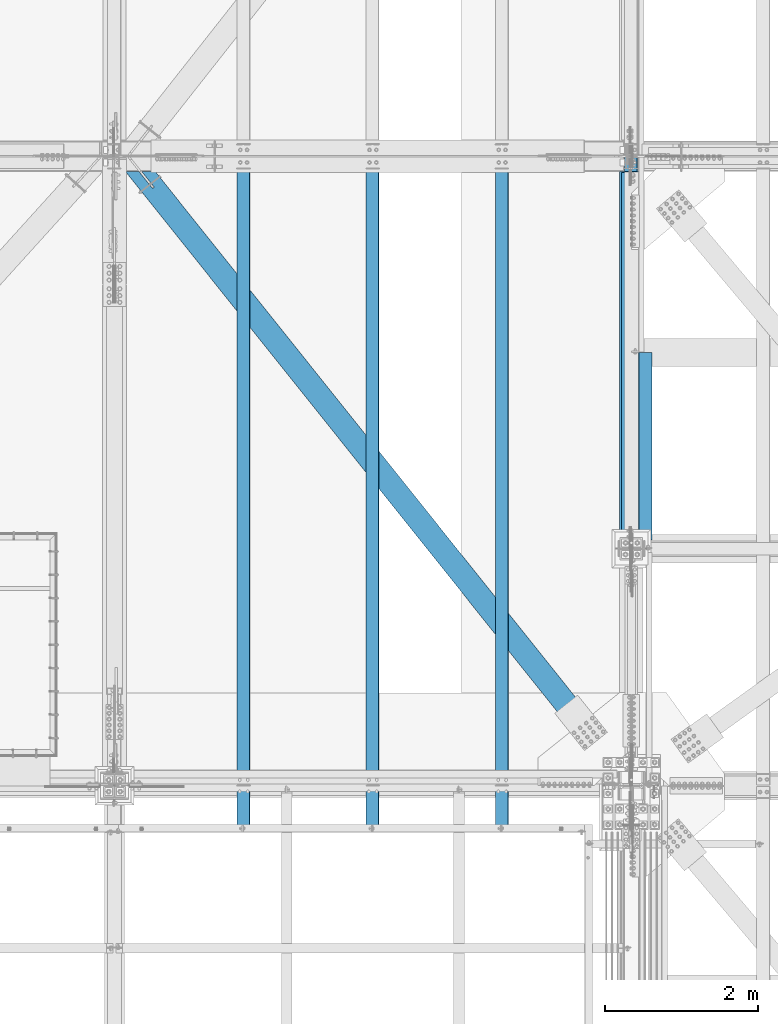
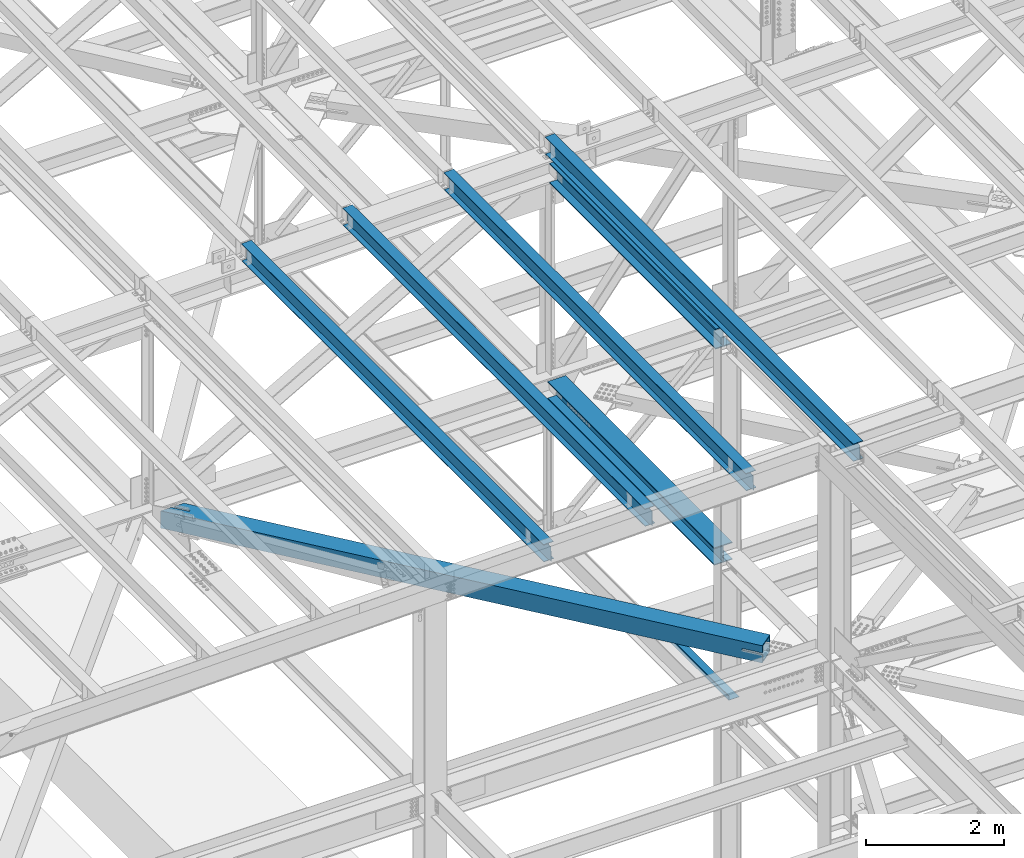
# One storey, part 1802 of 3843: 8 beams, 8 elements without a shape of their own.
"""IFC2X3 building model written with IfcOpenShell, lengths in millimetres."""

from ifc_helpers import new_model, si_unit, frame, origin_with_axes, place, context, subcontext, project, spatial, faceted_brep, material, type_object, element, aggregate, save


model = new_model("IFC2X3")

# Units and contexts
model_context = context("Model", 3, precision=1e-05, world=origin_with_axes())
body_context = subcontext(model_context, "Body", "Model", "MODEL_VIEW")
ifc_project = project(units=[si_unit("LENGTHUNIT", "METRE", prefix="MILLI"), si_unit("AREAUNIT", "SQUARE_METRE"), si_unit("VOLUMEUNIT", "CUBIC_METRE"), si_unit("MASSUNIT", "GRAM", prefix="KILO"), si_unit("TIMEUNIT", "SECOND"), si_unit("PLANEANGLEUNIT", "RADIAN"), si_unit("SOLIDANGLEUNIT", "STERADIAN"), si_unit("THERMODYNAMICTEMPERATUREUNIT", "DEGREE_CELSIUS"), si_unit("LUMINOUSINTENSITYUNIT", "LUMEN")], contexts=[model_context])

# Site, building, storey
site_placement = place(None, origin_with_axes())
site = spatial("IfcSite", under=ifc_project, at=site_placement, CompositionType="ELEMENT")
building_placement = place(site_placement, origin_with_axes())
building = spatial("IfcBuilding", under=site, at=building_placement, Name="Undefined", CompositionType="ELEMENT")
storey_placement = place(building_placement, origin_with_axes())
storey = spatial("IfcBuildingStorey", under=building, at=storey_placement, Name="Undefined", CompositionType="ELEMENT", Elevation=0.0)

# Assembly, beam
assembly_1_placement = place(storey_placement, origin_with_axes())
assembly_1 = element("IfcElementAssembly", 1, at=assembly_1_placement, inside=storey, Name="BEAM", AssemblyPlace="NOTDEFINED", PredefinedType="RIGID_FRAME")
ifc_material_1 = material(Name="STEEL/A992")
beam_type_1 = type_object("IfcBeamType", Name="W12X26", PredefinedType="NOTDEFINED")
beam_1_placement = place(assembly_1_placement, frame((75320.4092622759, 25005.9853702349, 46393.69347119), z_axis=(-0.021152098282546, -0.00202236699979404, 0.999774223897558), x_axis=(0.0, 0.999997954099553, 0.00202281900020155)))
beam_1 = element("IfcBeam", 2, at=beam_1_placement, type_object=beam_type_1, material=ifc_material_1, Name="BEAM", ObjectType="W12X26", context=body_context, shape_type="Brep", body=[
    faceted_brep([(20.6890464579228, -3.17499999946449, -130.175000019226), (20.6887747607652, 3.17500000055588, -130.175000019204), (77.7840105210125, 3.17500000055588, -130.175000018884), (77.7840105210162, -3.17499999946449, -130.175000018848), (82.6440900390589, 3.17500000058499, -131.141729941497), (82.6440900390626, -3.17499999946449, -131.141729941461), (86.7642665072199, 3.17500000058499, -133.894743842022), (86.7642665072199, -3.17499999944994, -133.894743841985), (89.5172804076938, 3.17500000061409, -138.014920310212), (89.5172804076974, -3.17499999942083, -138.014920310183), (90.4840103302849, -3.17499999942083, -142.874999828266), (90.4840103302813, 3.17500000062864, -142.874999828302), (90.4840103302158, 3.17500000062864, -146.050000000549), (90.4840103302158, 82.5500000010652, -146.050000000607), (90.4840103301649, 82.5500000011089, -155.575000000623), (90.4840103301758, -82.5499999997846, -155.575000000514), (90.4840103302231, -82.5499999998283, -146.050000000498), (90.4840103302158, -3.17499999939173, -146.050000000556), (8827.13158785976, -82.5500000004686, 146.049999971365), (8827.15085093943, -82.5500000005122, 155.574999971373), (90.484010334254, -82.5500000010652, 155.420462696282), (90.4840103342431, -82.5500000010652, 146.050000000017), (8827.1437868134, 82.5500000003958, 155.574999971279), (90.4840103342431, 82.5499999997992, 155.574999999917), (8827.12452373372, 82.5500000004395, 146.049999971256), (90.4840103342322, 82.5499999998428, 146.049999999908), (8827.12791994816, 3.17500000000291, 146.049999971314), (90.4840103342394, 3.17499999940628, 146.049999999959), (77.784010525178, -3.17500000057044, 130.174999981173), (77.7840105251707, 3.17499999946449, 130.174999981136), (21.2152989384304, 3.17499999946449, 130.174999980234), (21.2155706355879, -3.17500000057044, 130.174999980212), (82.6440900432135, -3.17500000057044, 131.141729903742), (82.6440900432099, 3.17499999946449, 131.141729903706), (86.7642665113563, -3.17500000058499, 133.894743804216), (86.7642665113526, 3.17499999943539, 133.894743804187), (89.5172804118192, -3.17500000059954, 138.014920272384), (89.5172804118156, 3.17499999943539, 138.014920272348), (90.4840103343886, -3.17500000061409, 142.874999790452), (90.4840103343849, 3.17499999943539, 142.874999790416), (90.4840103342394, -3.17500000062864, 146.049999999959), (8827.12819164533, -3.17500000003201, 146.049999971314), (8826.53718550493, 3.17500000122527, -146.050000029201), (8826.53745720208, -3.1749999987951, -146.050000029194), (8826.54085341652, -82.5499999992317, -146.05000002915), (8826.52159033686, -82.549999999188, -155.575000029159), (8826.51452621082, 82.5500000017055, -155.575000029276), (8826.5337892905, 82.5500000016764, -146.050000029252), (20.7233868324729, 3.17500000049768, -113.060395883127), (21.1897445320101, 3.1749999995227, 117.539132543461)], [[[0, 1, 2, 3]], [[3, 2, 4, 5]], [[5, 4, 6, 7]], [[7, 6, 8, 9]], [[10, 11, 12, 13, 14, 15, 16, 17]], [[9, 8, 11, 10]], [[18, 19, 20, 21]], [[19, 22, 23, 20]], [[22, 24, 25, 23]], [[24, 26, 27, 25]], [[28, 29, 30, 31]], [[32, 33, 29, 28]], [[34, 35, 33, 32]], [[36, 37, 35, 34]], [[38, 39, 37, 36]], [[20, 23, 25, 27, 39, 38, 40, 21]], [[41, 18, 21, 40]], [[42, 26, 24, 22, 19, 18, 41, 43, 44, 45, 46, 47]], [[44, 43, 17, 16]], [[45, 44, 16, 15]], [[46, 45, 15, 14]], [[47, 46, 14, 13]], [[42, 47, 13, 12]], [[6, 4, 2, 1, 48, 49, 30, 29, 33, 35, 37, 39, 27, 26, 42, 12, 11, 8]], [[31, 30, 49, 48, 1, 0]], [[43, 41, 40, 38, 36, 34, 32, 28, 31, 0, 3, 5, 7, 9, 10, 17]]]),
])
aggregate(assembly_1, [beam_1])

assembly_2_placement = place(storey_placement, origin_with_axes())
assembly_2 = element("IfcElementAssembly", 3, at=assembly_2_placement, inside=storey, Name="BEAM", AssemblyPlace="NOTDEFINED", PredefinedType="RIGID_FRAME")
beam_2_placement = place(assembly_2_placement, frame((77009.5092622784, 24866.2620305877, 46429.4293898956), z_axis=(-0.0211520979065535, -0.00217161999968084, 0.999773910852213), x_axis=(0.0, 0.999997639304329, 0.00217287500066101)))
beam_2 = element("IfcBeam", 4, at=beam_2_placement, type_object=beam_type_1, material=ifc_material_1, Name="BEAM", ObjectType="W12X26", context=body_context, shape_type="Brep", body=[
    faceted_brep([(3.23033224151368, -3.17500000062864, -130.174999994553), (3.23004038932413, 3.17499999939173, -130.174999994582), (41.2712136226364, 3.17499999940628, -130.174999994691), (41.2712136226546, -3.17500000062864, -130.174999994684), (46.1312931406901, 3.17499999942083, -131.141729917275), (46.1312931407047, -3.17500000062864, -131.141729917261), (50.2514696088474, 3.17499999939173, -133.894743817735), (50.251469608862, -3.17500000064319, -133.894743817727), (53.0044835093213, 3.17499999937718, -138.014920285874), (53.0044835093358, -3.1750000006723, -138.014920285859), (53.9712134319125, -3.1750000006723, -142.874999803884), (53.9712134318943, 3.17499999936263, -142.874999803891), (53.9712134316578, 3.17499999933352, -146.04999999977), (53.9712134316542, 82.5499999997846, -146.050000000017), (53.9712134316396, 82.549999999741, -155.574999999997), (53.9712134316433, -82.5500000011816, -155.574999999473), (53.9712134316578, -82.5500000011525, -146.049999999501), (53.9712134316578, -3.1750000007014, -146.049999999741), (8966.88020895593, -82.5499999996537, 146.049999992385), (8966.90090100868, -82.54999999961, 155.574999992365), (53.9712134324291, -82.5499999997701, 155.574999999917), (53.9712134324145, -82.5499999997992, 146.049999999923), (8966.89331285175, 82.5500000013126, 155.574999991841), (53.9712134324254, 82.5500000011525, 155.574999999386), (8966.87262079899, 82.5500000012689, 146.049999991861), (53.9712134324109, 82.5500000011089, 146.049999999406), (8966.87626895136, 3.17500000083237, 146.049999992108), (53.9712134324109, 3.1750000006723, 146.049999999654), (41.2712136233276, -3.17499999943539, 130.17500000375), (41.2712136233094, 3.17500000059954, 130.175000003743), (3.79562316488591, 3.17500000058499, 130.175000004019), (3.79591501707546, -3.17499999944994, 130.175000004056), (46.1312931413704, -3.17499999942083, 131.141729926334), (46.1312931413559, 3.17500000061409, 131.141729926327), (50.2514696095313, -3.17499999943539, 133.894743826801), (50.2514696095168, 3.17500000059954, 133.894743826786), (53.0044835100198, -3.17499999940628, 138.014920294918), (53.0044835100052, 3.17500000061409, 138.014920294918), (53.9712134326219, -3.17499999937718, 142.874999812935), (53.9712134326037, 3.17500000065775, 142.874999812921), (53.9712134324109, -3.17499999937718, 146.049999999675), (8966.87656080355, -3.17499999921711, 146.04999999213), (8966.24171266658, 3.17499999947904, -146.050000007315), (8966.24200451877, -3.17500000054133, -146.050000007293), (8966.24565267114, -82.5500000009924, -146.050000007046), (8966.22496061837, -82.5500000010361, -155.575000007033), (8966.21737246144, 82.549999999901, -155.57500000755), (8966.23806451421, 82.5499999999302, -146.05000000757)], [[[0, 1, 2, 3]], [[3, 2, 4, 5]], [[5, 4, 6, 7]], [[7, 6, 8, 9]], [[10, 11, 12, 13, 14, 15, 16, 17]], [[9, 8, 11, 10]], [[18, 19, 20, 21]], [[19, 22, 23, 20]], [[22, 24, 25, 23]], [[24, 26, 27, 25]], [[28, 29, 30, 31]], [[32, 33, 29, 28]], [[34, 35, 33, 32]], [[36, 37, 35, 34]], [[38, 39, 37, 36]], [[20, 23, 25, 27, 39, 38, 40, 21]], [[41, 18, 21, 40]], [[42, 26, 24, 22, 19, 18, 41, 43, 44, 45, 46, 47]], [[44, 43, 17, 16]], [[45, 44, 16, 15]], [[46, 45, 15, 14]], [[47, 46, 14, 13]], [[42, 47, 13, 12]], [[6, 4, 2, 1, 30, 29, 33, 35, 37, 39, 27, 26, 42, 12, 11, 8]], [[31, 30, 1, 0]], [[43, 41, 40, 38, 36, 34, 32, 28, 31, 0, 3, 5, 7, 9, 10, 17]]]),
])
aggregate(assembly_2, [beam_2])

assembly_3_placement = place(storey_placement, origin_with_axes())
assembly_3 = element("IfcElementAssembly", 5, at=assembly_3_placement, inside=storey, Name="BEAM", AssemblyPlace="NOTDEFINED", PredefinedType="RIGID_FRAME")
beam_3_placement = place(assembly_3_placement, frame((73631.3092622721, 25005.9853702349, 46357.9574308909), z_axis=(-0.021152098282546, -0.00202236699979404, 0.999774223897558), x_axis=(0.0, 0.999997954099553, 0.00202281900020155)))
beam_3 = element("IfcBeam", 6, at=beam_3_placement, type_object=beam_type_1, material=ifc_material_1, Name="BEAM", ObjectType="W12X26", context=body_context, shape_type="Brep", body=[
    faceted_brep([(20.6890464579228, -3.17499999946449, -130.175000019226), (20.6887747607652, 3.17500000055588, -130.175000019204), (77.7840105210125, 3.17500000055588, -130.175000018884), (77.7840105210162, -3.17499999946449, -130.175000018848), (82.6440900390589, 3.17500000058499, -131.141729941497), (82.6440900390626, -3.17499999946449, -131.141729941461), (86.7642665072199, 3.17500000058499, -133.894743842022), (86.7642665072199, -3.17499999944994, -133.894743841985), (89.5172804076938, 3.17500000061409, -138.014920310212), (89.5172804076974, -3.17499999942083, -138.014920310183), (90.4840103302849, -3.17499999942083, -142.874999828266), (90.4840103302813, 3.17500000062864, -142.874999828302), (90.4840103302158, 3.17500000062864, -146.050000000549), (90.4840103302158, 82.5500000010652, -146.050000000607), (90.4840103301649, 82.5500000011089, -155.575000000623), (90.4840103301758, -82.5499999997846, -155.575000000514), (90.4840103302231, -82.5499999998283, -146.050000000498), (90.4840103302158, -3.17499999939173, -146.050000000556), (8827.13158785976, -82.5500000004686, 146.049999971365), (8827.15085093943, -82.5500000005122, 155.574999971373), (90.484010334254, -82.5500000010652, 155.420462696282), (90.4840103342431, -82.5500000010652, 146.050000000017), (8827.1437868134, 82.5500000003958, 155.574999971279), (90.4840103342431, 82.5499999997992, 155.574999999917), (8827.12452373372, 82.5500000004395, 146.049999971256), (90.4840103342322, 82.5499999998428, 146.049999999908), (8827.12791994816, 3.17500000000291, 146.049999971314), (90.4840103342394, 3.17499999940628, 146.049999999959), (77.784010525178, -3.17500000057044, 130.174999981173), (77.7840105251707, 3.17499999946449, 130.174999981136), (21.2152989384304, 3.17499999946449, 130.174999980234), (21.2155706355879, -3.17500000057044, 130.174999980212), (82.6440900432135, -3.17500000057044, 131.141729903742), (82.6440900432099, 3.17499999946449, 131.141729903706), (86.7642665113563, -3.17500000058499, 133.894743804216), (86.7642665113526, 3.17499999943539, 133.894743804187), (89.5172804118192, -3.17500000059954, 138.014920272384), (89.5172804118156, 3.17499999943539, 138.014920272348), (90.4840103343886, -3.17500000061409, 142.874999790452), (90.4840103343849, 3.17499999943539, 142.874999790416), (90.4840103342394, -3.17500000062864, 146.049999999959), (8827.12819164533, -3.17500000003201, 146.049999971314), (8826.53718550493, 3.17500000122527, -146.050000029201), (8826.53745720208, -3.1749999987951, -146.050000029194), (8826.54085341652, -82.5499999992317, -146.05000002915), (8826.52159033686, -82.549999999188, -155.575000029159), (8826.51452621082, 82.5500000017055, -155.575000029276), (8826.5337892905, 82.5500000016764, -146.050000029252), (20.7233868324729, 3.17500000049768, -113.060395883127), (21.1897445320101, 3.1749999995227, 117.539132543461)], [[[0, 1, 2, 3]], [[3, 2, 4, 5]], [[5, 4, 6, 7]], [[7, 6, 8, 9]], [[10, 11, 12, 13, 14, 15, 16, 17]], [[9, 8, 11, 10]], [[18, 19, 20, 21]], [[19, 22, 23, 20]], [[22, 24, 25, 23]], [[24, 26, 27, 25]], [[28, 29, 30, 31]], [[32, 33, 29, 28]], [[34, 35, 33, 32]], [[36, 37, 35, 34]], [[38, 39, 37, 36]], [[20, 23, 25, 27, 39, 38, 40, 21]], [[41, 18, 21, 40]], [[42, 26, 24, 22, 19, 18, 41, 43, 44, 45, 46, 47]], [[44, 43, 17, 16]], [[45, 44, 16, 15]], [[46, 45, 15, 14]], [[47, 46, 14, 13]], [[42, 47, 13, 12]], [[6, 4, 2, 1, 48, 49, 30, 29, 33, 35, 37, 39, 27, 26, 42, 12, 11, 8]], [[31, 30, 49, 48, 1, 0]], [[43, 41, 40, 38, 36, 34, 32, 28, 31, 0, 3, 5, 7, 9, 10, 17]]]),
])
aggregate(assembly_3, [beam_3])

assembly_4_placement = place(storey_placement, origin_with_axes())
assembly_4 = element("IfcElementAssembly", 7, at=assembly_4_placement, inside=storey, Name="BEAM", AssemblyPlace="NOTDEFINED", PredefinedType="RIGID_FRAME")
beam_4_placement = place(assembly_4_placement, frame((71942.2092622726, 25005.9997106047, 46322.2214552547), z_axis=(-0.0211520984278469, -0.00193019000019922, 0.999774406103028), x_axis=(0.0, 0.999998136347609, 0.00193062200067138)))
beam_4 = element("IfcBeam", 8, at=beam_4_placement, type_object=beam_type_1, material=ifc_material_1, Name="BEAM", ObjectType="W12X26", context=body_context, shape_type="Brep", body=[
    faceted_brep([(20.6866951797929, -3.17500000080327, -130.17500002055), (20.6864358662206, 3.17499999924621, -130.175000020594), (77.7841677181023, 3.17499999924621, -130.175000022602), (77.7841677181132, -3.17500000080327, -130.175000022668), (82.6442472361523, 3.17499999924621, -131.1417299452), (82.6442472361632, -3.17500000080327, -131.141729945273), (86.7644237043132, 3.17499999923166, -133.894743845696), (86.7644237043241, -3.17500000081782, -133.894743845769), (89.517437604798, 3.17499999920256, -138.014920313864), (89.5174376048053, -3.17500000083237, -138.014920313937), (90.4841675274001, -3.17500000087603, -142.874999831984), (90.4841675273892, 3.1749999991589, -142.874999831911), (90.4841675272546, 3.17499999914435, -146.050000000097), (90.4841675272473, 82.5499999995664, -146.049999999901), (90.4841675272146, 82.5499999995227, -155.574999999903), (90.4841675272219, -82.5500000013853, -155.575000000303), (90.4841675272583, -82.5500000013126, -146.050000000309), (90.4841675272583, -3.17500000089058, -146.050000000119), (8827.10201536487, -82.5499999991443, 146.049999979019), (8827.12040045944, -82.5499999991007, 155.574999979013), (90.4841675309763, -82.5499999994645, 155.427568903593), (90.4841675309726, -82.5499999995809, 146.049999999486), (8827.11365830664, 82.5500000018073, 155.574999979406), (90.4841675309654, 82.5500000013853, 155.574999999888), (8827.09527321207, 82.5500000017637, 146.049999979412), (90.4841675309654, 82.5500000013126, 146.049999999894), (8827.09851463169, 3.17500000131258, 146.049999979223), (90.484167530969, 3.17500000089058, 146.049999999705), (77.7841677220058, -3.17499999923166, 130.174999976618), (77.7841677219985, 3.17500000078871, 130.174999976683), (21.1889617846828, 3.17500000078871, 130.17499997811), (21.1892210982514, -3.17499999923166, 130.174999978146), (82.6442472400413, -3.17499999923166, 131.141729899187), (82.644247240034, 3.17500000078871, 131.141729899253), (86.7644237081804, -3.17499999921711, 133.894743799647), (86.7644237081731, 3.17500000081782, 133.894743799719), (89.5174376086397, -3.17499999920256, 138.014920267786), (89.5174376086325, 3.17500000083237, 138.014920267859), (90.4841675312091, -3.17499999917345, 142.874999785818), (90.4841675311982, 3.17500000086147, 142.87499978589), (90.4841675309726, -3.1749999991589, 146.049999999683), (8827.09877394526, -3.17499999872234, 146.049999979208), (8826.53470506463, 3.1749999995809, -146.050000020572), (8826.5349643782, -3.17500000046857, -146.050000020587), (8826.53820579782, -82.5500000008906, -146.050000020776), (8826.51982070324, -82.5500000009488, -155.575000020777), (8826.51307855044, 82.5499999999447, -155.57500002037), (8826.53146364502, 82.5500000000029, -146.050000020376), (20.7194646498574, 3.17499999933352, -113.063357609572), (21.1645664778953, 3.17500000071595, 117.536212827035)], [[[0, 1, 2, 3]], [[3, 2, 4, 5]], [[5, 4, 6, 7]], [[7, 6, 8, 9]], [[10, 11, 12, 13, 14, 15, 16, 17]], [[9, 8, 11, 10]], [[18, 19, 20, 21]], [[19, 22, 23, 20]], [[22, 24, 25, 23]], [[24, 26, 27, 25]], [[28, 29, 30, 31]], [[32, 33, 29, 28]], [[34, 35, 33, 32]], [[36, 37, 35, 34]], [[38, 39, 37, 36]], [[20, 23, 25, 27, 39, 38, 40, 21]], [[41, 18, 21, 40]], [[42, 26, 24, 22, 19, 18, 41, 43, 44, 45, 46, 47]], [[44, 43, 17, 16]], [[45, 44, 16, 15]], [[46, 45, 15, 14]], [[47, 46, 14, 13]], [[42, 47, 13, 12]], [[6, 4, 2, 1, 48, 49, 30, 29, 33, 35, 37, 39, 27, 26, 42, 12, 11, 8]], [[31, 30, 49, 48, 1, 0]], [[43, 41, 40, 38, 36, 34, 32, 28, 31, 0, 3, 5, 7, 9, 10, 17]]]),
])
aggregate(assembly_4, [beam_4])

assembly_5_placement = place(storey_placement, origin_with_axes())
assembly_5 = element("IfcElementAssembly", 9, at=assembly_5_placement, inside=storey, Name="BENT_PLATE", AssemblyPlace="NOTDEFINED", PredefinedType="RIGID_FRAME")
ifc_material_2 = material(Name="STEEL/A36")
beam_type_2 = type_object("IfcBeamType", PredefinedType="NOTDEFINED")
beam_5_placement = place(assembly_5_placement, frame((77279.5000000003, 30054.55, 39627.1749999995), z_axis=(0.0, 1.0, 0.0), x_axis=(-1.0, 0.0, 0.0)))
beam_5 = element("IfcBeam", 10, at=beam_5_placement, type_object=beam_type_2, material=ifc_material_2, Name="BENT_PLATE", context=body_context, shape_type="Brep", body=[
    faceted_brep([(0.0, -3.17500000000291, -1225.55), (0.0, -3.17500000000291, 1225.55), (0.0, 3.17500000000291, 1225.55), (0.0, 3.17500000000291, -1225.55), (169.862500000338, 3.17500000000291, 1225.55), (169.862500000338, 3.17500000000291, -1225.55), (176.212500000329, -3.17500000000291, -1225.55), (176.212500000329, -3.17500000000291, 1225.55), (169.86250000041, 73.0249999998996, 1225.55), (169.86250000041, 73.0249999998996, -1225.55), (176.212500000416, 73.024999999885, 1225.55), (176.212500000416, 73.024999999885, -1225.55)], [[[0, 1, 2, 3]], [[3, 2, 4, 5]], [[1, 0, 6, 7]], [[5, 4, 8, 9]], [[4, 2, 1, 7, 10, 8]], [[7, 6, 11, 10]], [[6, 0, 3, 5, 9, 11]], [[10, 11, 9, 8]]]),
])
aggregate(assembly_5, [beam_5])

assembly_6_placement = place(storey_placement, origin_with_axes())
assembly_6 = element("IfcElementAssembly", 11, at=assembly_6_placement, inside=storey, AssemblyPlace="NOTDEFINED", PredefinedType="RIGID_FRAME")
ifc_material_3 = material()
beam_type_3 = type_object("IfcBeamType", Name="HSS12X12X3/4", PredefinedType="NOTDEFINED")
beam_6_placement = place(assembly_6_placement, frame((70434.2, 33845.4999998931, 42246.55), z_axis=(0.781103955949756, 0.624401000959833, 0.0), x_axis=(0.624401003155521, -0.781103954194561, 0.0)))
beam_6 = element("IfcBeam", 12, at=beam_6_placement, type_object=beam_type_3, material=ifc_material_3, ObjectType="HSS12X12X3/4", context=body_context, shape_type="Brep", body=[
    faceted_brep([(265.468671126146, -152.400000000001, 14.2875000030908), (265.468671126146, -133.349999999999, 14.2875000030908), (516.612150622008, -133.349999999999, 14.2874999980413), (516.612150622008, -152.400000000001, 14.2874999980413), (522.079740307912, -133.349999999999, 13.1999287896615), (522.079740307912, -152.400000000001, 13.1999287896615), (526.714939027981, -133.349999999999, 10.1027880223555), (526.714939027981, -152.400000000001, 10.1027880223555), (529.812079795269, -133.349999999999, 5.46758930226497), (529.812079795269, -152.400000000001, 5.46758930226497), (516.612150622397, -152.400000000001, -14.2874999926571), (516.612150622397, -133.349999999999, -14.2874999926571), (242.626310053987, -133.349999999999, -14.2874999877968), (242.626310053987, -152.400000000001, -14.2874999877968), (522.079740308236, -152.400000000001, -13.199928784481), (522.079740308236, -133.349999999999, -13.199928784481), (526.714939028217, -152.400000000001, -10.1027880173497), (526.714939028217, -133.349999999999, -10.1027880173497), (529.812079795382, -152.400000000001, -5.46758929740463), (529.812079795382, -133.349999999999, -5.46758929740463), (530.899651003598, -152.400000000001, 3.8840516936034e-07), (530.899651003598, -133.349999999999, 3.8840516936034e-07), (265.468671126146, 133.349999999999, 14.2875000030908), (265.468671126146, 152.400000000001, 14.2875000030908), (516.612150622008, 152.400000000001, 14.2874999980413), (516.612150622008, 133.349999999999, 14.2874999980413), (522.079740307912, 152.400000000001, 13.1999287896615), (522.079740307912, 133.349999999999, 13.1999287896615), (526.714939027981, 152.400000000001, 10.1027880223555), (526.714939027981, 133.349999999999, 10.1027880223555), (529.812079795269, 152.400000000001, 5.46758930226497), (529.812079795269, 133.349999999999, 5.46758930226497), (516.612150622397, 133.349999999999, -14.2874999926571), (516.612150622397, 152.400000000001, -14.2874999926571), (242.626310053987, 152.400000000001, -14.2874999877968), (242.626310053987, 133.349999999999, -14.2874999877968), (522.079740308236, 133.349999999999, -13.199928784481), (522.079740308236, 152.400000000001, -13.199928784481), (526.714939028217, 133.349999999999, -10.1027880173497), (526.714939028217, 152.400000000001, -10.1027880173497), (529.812079795382, 133.349999999999, -5.46758929740463), (529.812079795382, 152.400000000001, -5.46758929740463), (530.899651003598, 133.349999999999, 3.8840516936034e-07), (530.899651003598, 152.400000000001, 3.8840516936034e-07), (9475.67687284442, -26.9874999999956, -133.350000060527), (9475.67687284461, -26.9874999999956, -152.400000060486), (9172.46437321015, -26.9874999999956, -152.400000058551), (9172.46437320989, -26.9874999999956, -133.350000058592), (9166.9967835243, -25.8999287917104, -152.400000058507), (9166.99678352403, -25.8999287917104, -133.350000058548), (9162.36158480428, -22.8027880244699, -152.400000058478), (9162.36158480401, -22.8027880244699, -133.350000058519), (9159.26444403705, -18.167589304423, -152.400000058464), (9159.26444403679, -18.167589304423, -133.35000005849), (9158.17687282878, -12.6999996185259, -152.400000058449), (9158.17687282851, -12.6999996185259, -133.35000005849), (9159.26444403705, -7.23241069557116, -152.400000058464), (9159.26444403679, -7.23241069557116, -133.35000005849), (9162.36158480428, -2.59721197552426, -152.400000058478), (9162.36158480401, -2.59721197552426, -133.350000058519), (9166.9967835243, 0.499928791716229, -152.400000058507), (9166.99678352403, 0.499928791716229, -133.350000058548), (9172.46437321015, 1.58750000000146, -152.400000058551), (9172.46437320989, 1.58750000000146, -133.350000058592), (9475.67687284442, 1.58750000000146, -133.350000060527), (9475.67687284461, 1.58750000000146, -152.400000060486), (9475.6768728417, 133.349999999999, 133.349999938859), (9475.67687284442, 133.349999999999, -133.350000060527), (9475.67687284461, 152.400000000001, -152.400000060486), (9475.6768728415, 152.400000000001, 152.399999938803), (9475.6768728415, 1.58750000000146, 152.399999938803), (9475.6768728417, 1.58750000000146, 133.349999938859), (9475.67687284442, -133.349999999999, -133.350000060527), (147.449805546054, 133.349999999999, -133.350000000632), (147.449805546054, -133.349999999999, -133.350000000632), (360.645175619266, -133.349999999999, 133.349999997401), (9475.6768728417, -133.349999999999, 133.349999938859), (9172.46437320616, 1.58750000000146, 133.349999940794), (9166.99678352029, 0.499928791716229, 133.349999940838), (9162.36158480027, -2.59721197552426, 133.349999940852), (9159.26444403305, -7.23241069557116, 133.349999940881), (9158.17687282477, -12.6999996185259, 133.349999940896), (9159.26444403305, -18.167589304423, 133.349999940881), (9162.36158480027, -22.8027880244699, 133.349999940852), (9166.99678352029, -25.8999287917104, 133.349999940838), (9172.46437320616, -26.9874999999956, 133.349999940794), (9475.6768728417, -26.9874999999956, 133.349999938859), (360.645175619266, 133.349999999999, 133.349999997401), (9172.46437320589, 1.58750000000146, 152.399999940753), (9166.99678352002, 0.499928791716229, 152.399999940782), (9162.3615848, -2.59721197552426, 152.399999940826), (9159.26444403278, -7.23241069557116, 152.399999940841), (9158.17687282451, -12.6999996185259, 152.399999940855), (9159.26444403278, -18.167589304423, 152.399999940841), (9162.3615848, -22.8027880244699, 152.399999940826), (9166.99678352002, -25.8999287917104, 152.399999940782), (9172.46437320589, -26.9874999999956, 152.399999940753), (9475.6768728415, -26.9874999999956, 152.399999938803), (9475.6768728415, -152.400000000001, 152.399999938803), (9475.67687284461, -152.400000000001, -152.400000060486), (132.221564826541, -152.400000000001, -152.400000000489), (132.221564826541, 152.400000000001, -152.400000000489), (375.873416338774, 152.400000000001, 152.399999997244), (375.873416338774, -152.400000000001, 152.399999997244)], [[[0, 1, 2, 3]], [[3, 2, 4, 5]], [[5, 4, 6, 7]], [[7, 6, 8, 9]], [[10, 11, 12, 13]], [[14, 15, 11, 10]], [[16, 17, 15, 14]], [[18, 19, 17, 16]], [[20, 21, 19, 18]], [[9, 8, 21, 20]], [[22, 23, 24, 25]], [[25, 24, 26, 27]], [[27, 26, 28, 29]], [[29, 28, 30, 31]], [[32, 33, 34, 35]], [[36, 37, 33, 32]], [[38, 39, 37, 36]], [[40, 41, 39, 38]], [[42, 43, 41, 40]], [[31, 30, 43, 42]], [[44, 45, 46, 47]], [[47, 46, 48, 49]], [[49, 48, 50, 51]], [[51, 50, 52, 53]], [[53, 52, 54, 55]], [[55, 54, 56, 57]], [[57, 56, 58, 59]], [[59, 58, 60, 61]], [[61, 60, 62, 63]], [[64, 63, 62, 65]], [[66, 67, 64, 65, 68, 69, 70, 71]], [[72, 44, 47, 49, 51, 53, 55, 57, 59, 61, 63, 64, 67, 73, 74]], [[6, 4, 2, 1, 75, 76, 72, 74, 12, 11, 15, 17, 19, 21, 8]], [[66, 71, 77, 78, 79, 80, 81, 82, 83, 84, 85, 86, 76, 75, 87]], [[70, 88, 77, 71]], [[89, 78, 77, 88]], [[90, 79, 78, 89]], [[91, 80, 79, 90]], [[92, 81, 80, 91]], [[93, 82, 81, 92]], [[94, 83, 82, 93]], [[95, 84, 83, 94]], [[96, 85, 84, 95]], [[97, 86, 85, 96]], [[98, 99, 45, 44, 72, 76, 86, 97]], [[68, 65, 62, 60, 58, 56, 54, 52, 50, 48, 46, 45, 99, 100, 101]], [[74, 73, 35, 34, 101, 100, 13, 12]], [[28, 26, 24, 23, 102, 69, 68, 101, 34, 33, 37, 39, 41, 43, 30]], [[98, 97, 96, 95, 94, 93, 92, 91, 90, 89, 88, 70, 69, 102, 103]], [[16, 14, 10, 13, 100, 99, 98, 103, 0, 3, 5, 7, 9, 20, 18]], [[103, 102, 23, 22, 87, 75, 1, 0]], [[38, 36, 32, 35, 73, 67, 66, 87, 22, 25, 27, 29, 31, 42, 40]]]),
])
aggregate(assembly_6, [beam_6])

assembly_7_placement = place(storey_placement, origin_with_axes())
assembly_7 = element("IfcElementAssembly", 13, at=assembly_7_placement, inside=storey, Name="BEAM", AssemblyPlace="NOTDEFINED", PredefinedType="RIGID_FRAME")
beam_type_4 = type_object("IfcBeamType", Name="W14X68", PredefinedType="NOTDEFINED")
beam_7_placement = place(assembly_7_placement, frame((77012.8, 28714.7, 46076.9955507418), z_axis=(0.0, -0.00380210699986492, 0.999992771965059), x_axis=(0.0, 0.999992771965059, 0.00380210699986645)))
beam_7 = element("IfcBeam", 14, at=beam_7_placement, type_object=beam_type_4, material=ifc_material_1, Name="BEAM", ObjectType="W14X68", context=body_context, shape_type="Brep", body=[
    faceted_brep([(113.697237315562, -127.0, -158.749999999527), (113.624806653683, -127.0, -177.799999999472), (4917.43452876816, -127.0, -177.800000001233), (4917.50695943004, -127.0, -158.750000001295), (113.697237315562, -5.55624999999418, -158.749999999527), (4917.50695943004, -5.55624999999418, -158.750000001295), (114.904415013545, -5.55624999999418, 158.749999999454), (4918.71413712801, -5.55624999999418, 158.749999997686), (114.904415013545, -127.0, 158.749999999454), (4918.71413712801, -127.0, 158.749999997686), (114.976845675425, -127.0, 177.799999999384), (4918.78656778989, -127.0, 177.799999997624), (114.976845675425, 127.0, 177.799999999384), (4918.78656778989, 127.0, 177.799999997624), (114.904415013545, 127.0, 158.749999999454), (4918.71413712801, 127.0, 158.749999997686), (114.904415013545, 5.55624999999418, 158.749999999454), (4918.71413712801, 5.55624999999418, 158.749999997686), (113.697237315562, 5.55624999999418, -158.749999999527), (113.912365995111, 5.55624999999418, -102.168971481369), (114.83544153253, 5.55624999999418, 140.609273693568), (4917.50695943004, 5.55624999999418, -158.750000001295), (113.697237315562, 127.0, -158.749999999527), (4917.50695943004, 127.0, -158.750000001295), (113.624806653683, 127.0, -177.799999999472), (4917.43452876816, 127.0, -177.800000001233)], [[[0, 1, 2, 3]], [[4, 0, 3, 5]], [[6, 4, 5, 7]], [[8, 6, 7, 9]], [[10, 8, 9, 11]], [[12, 10, 11, 13]], [[14, 12, 13, 15]], [[16, 14, 15, 17]], [[18, 19, 20, 16, 17, 21]], [[22, 18, 21, 23]], [[1, 0, 4, 6, 8, 10, 12, 14, 16, 20, 19, 18, 22, 24]], [[1, 24, 25, 2]], [[21, 17, 15, 13, 11, 9, 7, 5, 3, 2, 25, 23]], [[24, 22, 23, 25]]]),
])
aggregate(assembly_7, [beam_7])

assembly_8_placement = place(storey_placement, origin_with_axes())
assembly_8 = element("IfcElementAssembly", 15, at=assembly_8_placement, inside=storey, Name="BEAM", AssemblyPlace="NOTDEFINED", PredefinedType="RIGID_FRAME")
beam_type_5 = type_object("IfcBeamType", Name="W12X65", PredefinedType="NOTDEFINED")
beam_8_placement = place(assembly_8_placement, frame((77012.8, 28714.7, 42246.55), z_axis=(0.0, -0.00380512900179746, 0.999992760470435), x_axis=(0.0, 0.999992760470435, 0.00380512900178651)))
beam_8 = element("IfcBeam", 16, at=beam_8_placement, type_object=beam_type_5, material=ifc_material_1, Name="BEAM", ObjectType="W12X65", context=body_context, shape_type="Brep", body=[
    faceted_brep([(113.714880942542, 146.049999999988, -153.987500000272), (113.714880942542, -146.050000000017, -153.987500000272), (113.714880942542, -152.399999999994, -153.987500000272), (113.775287802764, -152.399999999994, -138.112500000228), (113.775287802764, -146.050000000017, -138.112500000228), (113.775287802764, -4.76249999999709, -138.112500000228), (114.826367170601, -4.76249999999709, 138.112500000512), (114.826367170601, -146.050000000017, 138.112500000512), (114.826367170601, -152.399999999994, 138.112500000512), (114.886774030823, -152.399999999994, 153.987500000549), (114.886774030823, -146.050000000017, 153.987500000549), (114.886774030823, 146.049999999988, 153.987500000549), (114.886774030823, 152.399999999994, 153.987500000549), (114.826367170601, 152.399999999994, 138.112500000512), (114.826367170601, 146.049999999988, 138.112500000512), (114.826367170601, 4.76249999999709, 138.112500000512), (114.744614411313, 4.76249999999709, 116.62777046844), (113.869130330586, 4.76249999999709, -113.450563860722), (113.775287802764, 4.76249999999709, -138.112500000228), (113.775287802764, 146.049999999988, -138.112500000228), (113.775287802764, 152.399999999994, -138.112500000228), (113.714880942542, 152.399999999994, -153.987500000272), (4931.81226168903, -152.399999999994, -153.987499994364), (4931.87266854925, -152.399999999994, -138.11249999432), (4931.87266854925, -4.76249999999709, -138.11249999432), (4932.92374791709, -4.76249999999709, 138.11250000642), (4932.92374791709, -152.399999999994, 138.11250000642), (4932.9841547773, -152.399999999994, 153.987500006464), (4932.9841547773, 152.399999999994, 153.987500006464), (4932.92374791709, 152.399999999994, 138.11250000642), (4932.92374791709, 4.76249999999709, 138.11250000642), (4931.87266854925, 4.76249999999709, -138.11249999432), (4931.87266854925, 152.399999999994, -138.11249999432), (4931.81226168903, 152.399999999994, -153.987499994364)], [[[0, 1, 2, 3, 4, 5, 6, 7, 8, 9, 10, 11, 12, 13, 14, 15, 16, 17, 18, 19, 20, 21]], [[3, 2, 22, 23]], [[5, 4, 3, 23, 24]], [[6, 5, 24, 25]], [[8, 7, 6, 25, 26]], [[9, 8, 26, 27]], [[12, 11, 10, 9, 27, 28]], [[13, 12, 28, 29]], [[15, 14, 13, 29, 30]], [[18, 17, 16, 15, 30, 31]], [[20, 19, 18, 31, 32]], [[21, 20, 32, 33]], [[31, 30, 29, 28, 27, 26, 25, 24, 23, 22, 33, 32]], [[2, 1, 0, 21, 33, 22]]]),
])
aggregate(assembly_8, [beam_8])

save(model, "model.ifc")
